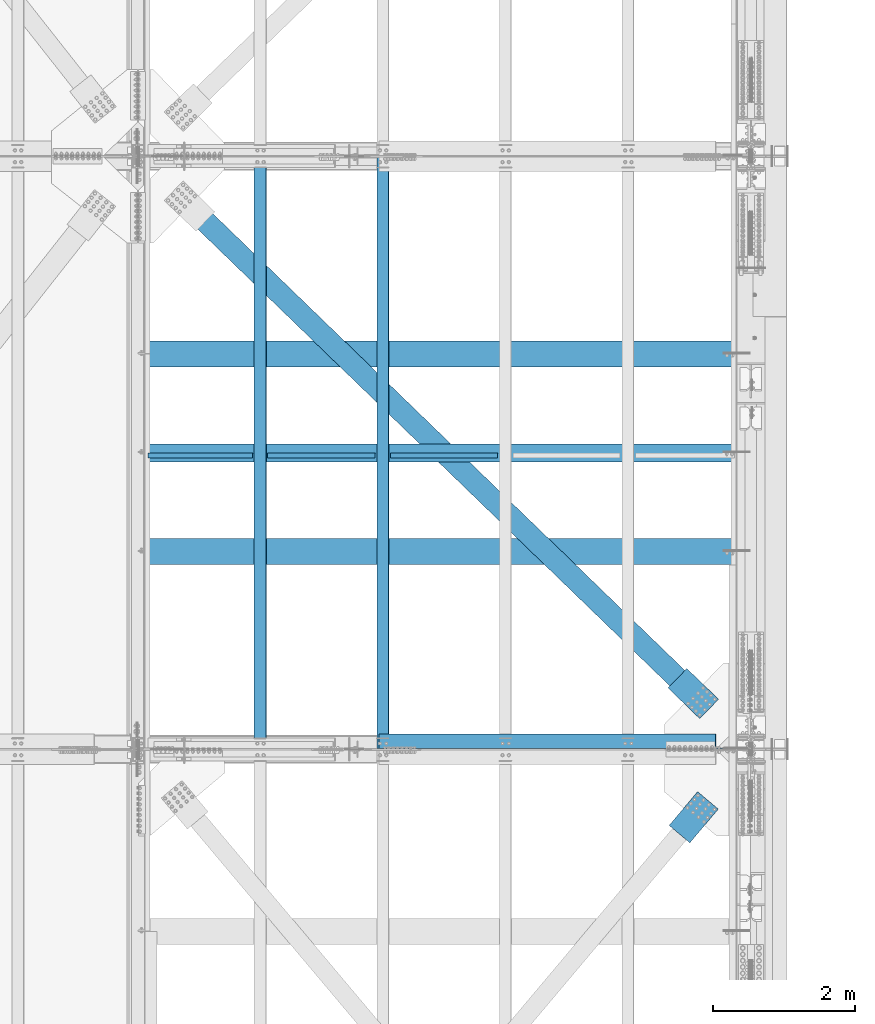
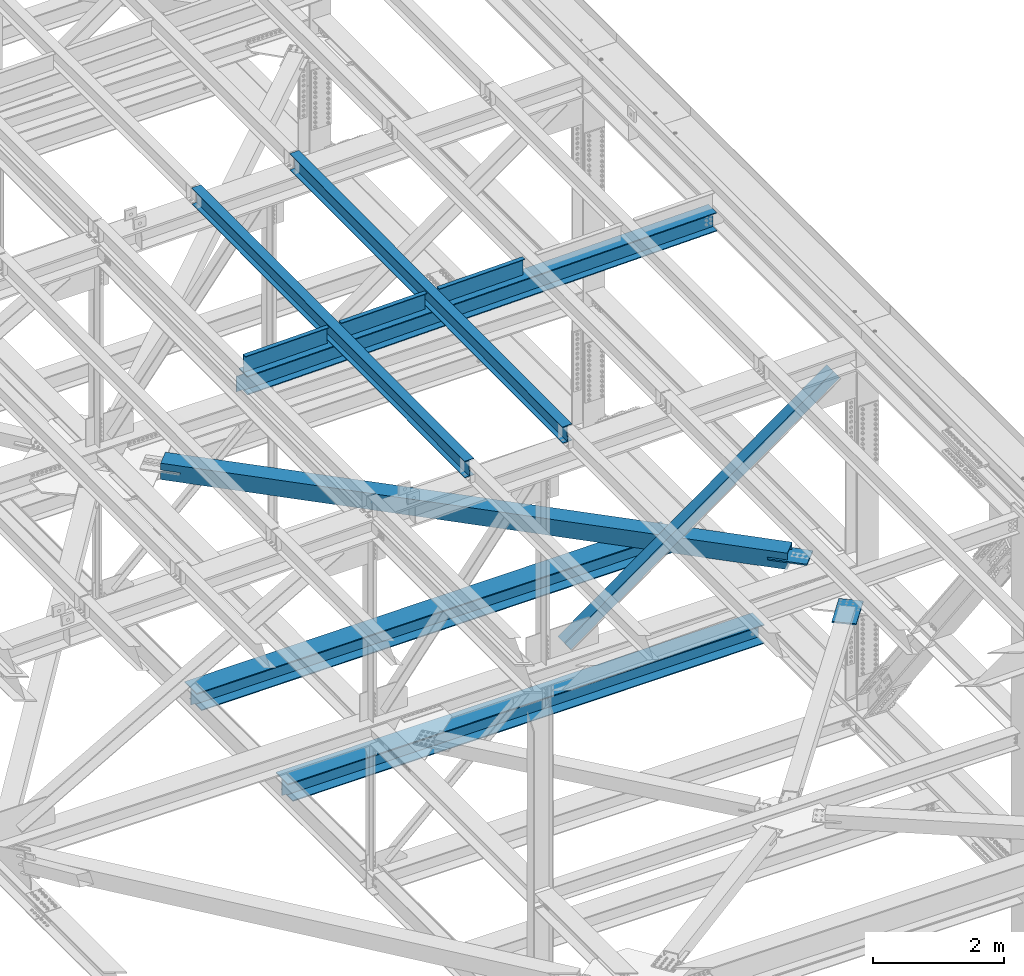
# One storey, part 1960 of 3843: 11 beams, 1 member, 11 elements without a shape of their own.
"""IFC2X3 building model written with IfcOpenShell, lengths in millimetres."""

from ifc_helpers import new_model, si_unit, frame, origin_with_axes, place, context, subcontext, project, spatial, faceted_brep, material, type_object, element, aggregate, save


model = new_model("IFC2X3")

# Units and contexts
model_context = context("Model", 3, precision=1e-05, world=origin_with_axes())
body_context = subcontext(model_context, "Body", "Model", "MODEL_VIEW")
ifc_project = project(units=[si_unit("LENGTHUNIT", "METRE", prefix="MILLI"), si_unit("AREAUNIT", "SQUARE_METRE"), si_unit("VOLUMEUNIT", "CUBIC_METRE"), si_unit("MASSUNIT", "GRAM", prefix="KILO"), si_unit("TIMEUNIT", "SECOND"), si_unit("PLANEANGLEUNIT", "RADIAN"), si_unit("SOLIDANGLEUNIT", "STERADIAN"), si_unit("THERMODYNAMICTEMPERATUREUNIT", "DEGREE_CELSIUS"), si_unit("LUMINOUSINTENSITYUNIT", "LUMEN")], contexts=[model_context])

# Site, building, storey
site_placement = place(None, origin_with_axes())
site = spatial("IfcSite", under=ifc_project, at=site_placement, CompositionType="ELEMENT")
building_placement = place(site_placement, origin_with_axes())
building = spatial("IfcBuilding", under=site, at=building_placement, Name="Undefined", CompositionType="ELEMENT")
storey_placement = place(building_placement, origin_with_axes())
storey = spatial("IfcBuildingStorey", under=building, at=storey_placement, Name="Undefined", CompositionType="ELEMENT", Elevation=0.0)

# Assembly, beam
assembly_1_placement = place(storey_placement, origin_with_axes())
assembly_1 = element("IfcElementAssembly", 1, at=assembly_1_placement, inside=storey, Name="BEAM", AssemblyPlace="NOTDEFINED", PredefinedType="RIGID_FRAME")
ifc_material_1 = material(Name="STEEL/A992")
beam_type_1 = type_object("IfcBeamType", Name="W12X26", PredefinedType="NOTDEFINED")
beam_1_placement = place(assembly_1_placement, frame((80463.9092623644, 33844.6461896289, 46523.0633431853), z_axis=(-0.0211520976960747, -0.00548809500152129, 0.999761206276934), x_axis=(0.0, 0.999984933553015, 0.00548932299754643)))
beam_1 = element("IfcBeam", 2, at=beam_1_placement, type_object=beam_type_1, material=ifc_material_1, Name="BEAM", ObjectType="W12X26", context=body_context, shape_type="Brep", body=[
    faceted_brep([(12.6906062761627, 82.5500000000466, -155.575000000434), (12.7428811673817, 82.5500000000611, -146.050000000425), (8344.06840460598, 82.5500000001339, -146.05000000351), (8344.01612971476, 82.5500000001193, -155.575000003526), (12.7520975927982, 3.17499999961001, -146.050000000228), (8344.07762103139, 3.17499999968277, -146.050000003313), (14.3551942568884, 3.17500000036671, 146.050000000199), (8345.68071769549, 3.17500000043947, 146.049999997114), (14.3459778314718, 82.5500000008033, 146.050000000003), (8345.67150127007, 82.550000000876, 146.049999996918), (14.3982527226908, 82.5500000008469, 155.575000000012), (8345.72377616129, 82.5500000009197, 155.574999996934), (14.4174228875563, -82.5500000000902, 155.575000000426), (8345.74294632617, -82.5500000000175, 155.574999997341), (14.3651479963373, -82.5500000001193, 146.050000000418), (8345.69067143494, -82.5500000000466, 146.049999997318), (14.3559315709208, -3.17499999966822, 146.050000000214), (8345.68145500952, -3.17499999959546, 146.049999997122), (12.7528349068307, -3.17500000042492, -146.050000000214), (8344.07835834543, -3.17500000035216, -146.050000003299), (12.7620513322399, -82.550000000876, -146.050000000017), (8344.08757477084, -82.5500000008033, -146.050000003095), (12.7097764410209, -82.5500000008906, -155.575000000019), (8344.03529987962, -82.5500000008178, -155.575000003111)], [[[0, 1, 2, 3]], [[1, 4, 5, 2]], [[4, 6, 7, 5]], [[6, 8, 9, 7]], [[8, 10, 11, 9]], [[10, 12, 13, 11]], [[12, 14, 15, 13]], [[14, 16, 17, 15]], [[16, 18, 19, 17]], [[18, 20, 21, 19]], [[20, 22, 23, 21]], [[22, 0, 3, 23]], [[5, 7, 9, 11, 13, 15, 17, 19, 21, 23, 3, 2]], [[22, 20, 18, 16, 14, 12, 10, 8, 6, 4, 1, 0]]]),
])
aggregate(assembly_1, [beam_1])

assembly_2_placement = place(storey_placement, origin_with_axes())
assembly_2 = element("IfcElementAssembly", 3, at=assembly_2_placement, inside=storey, Name="BEAM", AssemblyPlace="NOTDEFINED", PredefinedType="RIGID_FRAME")
beam_2_placement = place(assembly_2_placement, frame((78736.7092623646, 33844.5952455108, 46486.5209759278), z_axis=(-0.0211520978613553, -0.0058155520005821, 0.999759355100512), x_axis=(0.0, 0.999983081967479, 0.00581685299981112)))
beam_2 = element("IfcBeam", 4, at=beam_2_placement, type_object=beam_type_1, material=ifc_material_1, Name="BEAM", ObjectType="W12X26", context=body_context, shape_type="Brep", body=[
    faceted_brep([(12.6900579014109, 82.549999999479, -155.575000000033), (12.7454519674648, 82.5499999995227, -146.050000000017), (8344.08640182665, 82.5499999992608, -146.049999987452), (8344.0310077606, 82.5499999992026, -155.574999987468), (12.7552183248699, 3.17499999908614, -146.050000000228), (8344.09616818406, 3.17499999882421, -146.049999987663), (14.4539696838547, 3.17500000091968, 146.050000000294), (8345.79491954304, 3.17500000065775, 146.05000001286), (14.4442033264422, 82.5500000013417, 146.050000000505), (8345.78515318563, 82.5500000010798, 146.050000013071), (14.4995973924961, 82.5500000013999, 155.575000000521), (8345.84054725168, 82.5500000011234, 155.575000013087), (14.5199114159041, -82.5499999994936, 155.575000000084), (8345.86086127509, -82.5499999997555, 155.57500001265), (14.4645173498502, -82.5499999995664, 146.050000000068), (8345.80546720904, -82.5499999998283, 146.050000012634), (14.454750992445, -3.17499999911524, 146.050000000279), (8345.79570085163, -3.17499999939173, 146.050000012845), (12.7559996334676, -3.17500000093423, -146.05000000025), (8344.09694949265, -3.17500000119617, -146.049999987685), (12.7657659908728, -82.5500000013708, -146.050000000461), (8344.10671585005, -82.5500000016327, -146.049999987896), (12.7103719248189, -82.550000001429, -155.575000000477), (8344.051321784, -82.5500000016909, -155.574999987912)], [[[0, 1, 2, 3]], [[1, 4, 5, 2]], [[4, 6, 7, 5]], [[6, 8, 9, 7]], [[8, 10, 11, 9]], [[10, 12, 13, 11]], [[12, 14, 15, 13]], [[14, 16, 17, 15]], [[16, 18, 19, 17]], [[18, 20, 21, 19]], [[20, 22, 23, 21]], [[22, 0, 3, 23]], [[5, 7, 9, 11, 13, 15, 17, 19, 21, 23, 3, 2]], [[22, 20, 18, 16, 14, 12, 10, 8, 6, 4, 1, 0]]]),
])
aggregate(assembly_2, [beam_2])

assembly_3_placement = place(storey_placement, origin_with_axes())
assembly_3 = element("IfcElementAssembly", 5, at=assembly_3_placement, inside=storey, Name="BENT_PLATE", AssemblyPlace="NOTDEFINED", PredefinedType="RIGID_FRAME")
ifc_material_2 = material(Name="STEEL/A36")
beam_type_2 = type_object("IfcBeamType", PredefinedType="NOTDEFINED")
beam_3_placement = place(assembly_3_placement, frame((77894.6595890267, 38019.037499995, 46316.557671359), z_axis=(-0.999817430718778, 0.0, -0.0191077269946473), x_axis=(-0.0191077269946443, 0.0, 0.999817430718778)))
beam_3 = element("IfcBeam", 6, at=beam_3_placement, type_object=beam_type_2, material=ifc_material_2, Name="BENT_PLATE", context=body_context, shape_type="Brep", body=[
    faceted_brep([(2.31375452131033e-09, -4.76249999999709, -736.599999997517), (-2.30647856369615e-09, -4.76249999999709, 736.599999997474), (-2.30647856369615e-09, 4.76249999999709, 736.599999997474), (2.31375452131033e-09, 4.76249999999709, -736.599999997517), (336.54999997931, 4.76249999995343, 736.599999998551), (336.549999983916, 4.76249999995343, -736.59999999647), (327.024999983958, -4.76250000004075, -736.599999996499), (327.024999979338, -4.76250000004075, 736.599999998522), (336.549999979303, -71.4375000011278, 736.599999998551), (336.549999983908, -71.4375000011278, -736.599999996455), (327.02499997933, -71.4375000011278, 736.599999998522), (327.024999983951, -71.4375000011278, -736.599999996499)], [[[0, 1, 2, 3]], [[3, 2, 4, 5]], [[1, 0, 6, 7]], [[5, 4, 8, 9]], [[4, 2, 1, 7, 10, 8]], [[7, 6, 11, 10]], [[6, 0, 3, 5, 9, 11]], [[10, 11, 9, 8]]]),
])
aggregate(assembly_3, [beam_3])

assembly_4_placement = place(storey_placement, origin_with_axes())
assembly_4 = element("IfcElementAssembly", 7, at=assembly_4_placement, inside=storey, Name="BENT_PLATE", AssemblyPlace="NOTDEFINED", PredefinedType="RIGID_FRAME")
beam_4_placement = place(assembly_4_placement, frame((79602.8130669715, 38019.0374999949, 46349.2025616298), z_axis=(-0.999817430718778, 0.0, -0.0191077269946473), x_axis=(-0.0191077269946443, 0.0, 0.999817430718778)))
beam_4 = element("IfcBeam", 8, at=beam_4_placement, type_object=beam_type_2, material=ifc_material_2, Name="BENT_PLATE", context=body_context, shape_type="Brep", body=[
    faceted_brep([(2.38651409745216e-09, -4.76249999999709, -755.649999997448), (-2.37923813983798e-09, -4.76249999999709, 755.649999997433), (-2.37923813983798e-09, 4.76249999999709, 755.649999997433), (2.38651409745216e-09, 4.76249999999709, -755.649999997448), (336.54999997891, 4.76249999995343, 755.649999998495), (336.549999983821, 4.76249999995343, -755.649999996385), (327.024999983856, -4.76250000004075, -755.649999996414), (327.024999978938, -4.76250000004075, 755.649999998466), (336.549999978997, -71.4375000010259, 755.649999998495), (336.549999983719, -71.4375000011714, -755.649999996371), (327.024999979025, -71.4375000010259, 755.649999998481), (327.024999983762, -71.4375000011714, -755.6499999964)], [[[0, 1, 2, 3]], [[3, 2, 4, 5]], [[1, 0, 6, 7]], [[5, 4, 8, 9]], [[4, 2, 1, 7, 10, 8]], [[7, 6, 11, 10]], [[6, 0, 3, 5, 9, 11]], [[10, 11, 9, 8]]]),
])
aggregate(assembly_4, [beam_4])

assembly_5_placement = place(storey_placement, origin_with_axes())
assembly_5 = element("IfcElementAssembly", 9, at=assembly_5_placement, inside=storey, Name="BENT_PLATE", AssemblyPlace="NOTDEFINED", PredefinedType="RIGID_FRAME")
beam_5_placement = place(assembly_5_placement, frame((81330.0130669715, 38019.0374999949, 46382.2114540998), z_axis=(-0.999817430718778, 0.0, -0.0191077269946473), x_axis=(-0.0191077269946443, 0.0, 0.999817430718778)))
beam_5 = element("IfcBeam", 10, at=beam_5_placement, type_object=beam_type_2, material=ifc_material_2, Name="BENT_PLATE", context=body_context, shape_type="Brep", body=[
    faceted_brep([(2.38651409745216e-09, -4.76249999999709, -755.649999997448), (-2.37923813983798e-09, -4.76249999999709, 755.649999997433), (-2.37923813983798e-09, 4.76249999999709, 755.649999997433), (2.38651409745216e-09, 4.76249999999709, -755.649999997448), (336.54999997891, 4.76249999995343, 755.649999998495), (336.549999983821, 4.76249999995343, -755.649999996385), (327.024999983856, -4.76250000004075, -755.649999996414), (327.024999978938, -4.76250000004075, 755.649999998466), (336.549999978997, -71.4375000010259, 755.649999998495), (336.549999983719, -71.4375000011714, -755.649999996371), (327.024999979025, -71.4375000010259, 755.649999998481), (327.024999983762, -71.4375000011714, -755.6499999964)], [[[0, 1, 2, 3]], [[3, 2, 4, 5]], [[1, 0, 6, 7]], [[5, 4, 8, 9]], [[4, 2, 1, 7, 10, 8]], [[7, 6, 11, 10]], [[6, 0, 3, 5, 9, 11]], [[10, 11, 9, 8]]]),
])
aggregate(assembly_5, [beam_5])

assembly_6_placement = place(storey_placement, origin_with_axes())
assembly_6 = element("IfcElementAssembly", 11, at=assembly_6_placement, inside=storey, AssemblyPlace="NOTDEFINED", PredefinedType="RIGID_FRAME")
ifc_material_3 = material(Name="STEEL/A572-50")
beam_type_3 = type_object("IfcBeamType", PredefinedType="NOTDEFINED")
beam_6_placement = place(assembly_6_placement, frame((85061.136272036, 34414.1510652771, 42259.2500000054), z_axis=(0.695386222991622, 0.718636208991341, 0.0), x_axis=(-0.718636212924515, 0.695386218926944, 0.0)))
beam_6 = element("IfcBeam", 12, at=beam_6_placement, type_object=beam_type_3, material=ifc_material_3, Name="PLATE", context=body_context, shape_type="Brep", body=[
    faceted_brep([(5.85714587941766e-10, 12.6999999999971, -190.500000000349), (-6.14818418398499e-10, 12.6999999999971, 190.500000000364), (622.299987794569, 12.6999999999971, 190.499999998057), (622.299987793129, 12.6999999999971, -190.500000002765), (-6.14818418398499e-10, -12.6999999999971, 190.500000000364), (622.299987794569, -12.6999999999971, 190.499999998057), (5.85714587941766e-10, -12.6999999999971, -190.500000000349), (622.299987793129, -12.6999999999971, -190.500000002765)], [[[0, 1, 2, 3]], [[1, 4, 5, 2]], [[4, 6, 7, 5]], [[6, 0, 3, 7]], [[5, 7, 3, 2]], [[6, 4, 1, 0]]]),
])

assembly_7_placement = place(storey_placement, origin_with_axes())
assembly_7 = element("IfcElementAssembly", 13, at=assembly_7_placement, inside=storey, AssemblyPlace="NOTDEFINED", PredefinedType="RIGID_FRAME")
beam_7_placement = place(assembly_7_placement, frame((85043.6867269005, 33126.4830499824, 42259.2500000046), z_axis=(-0.76510760520398, 0.643902440171669, 0.0), x_axis=(-0.643902440171663, -0.765107605203986, 0.0)))
beam_7 = element("IfcBeam", 14, at=beam_7_placement, type_object=beam_type_3, material=ifc_material_3, Name="PLATE", context=body_context, shape_type="Brep", body=[
    faceted_brep([(5.85714587941766e-10, 12.6999999999971, -190.500000000349), (-6.14818418398499e-10, 12.6999999999971, 190.500000000364), (622.299987794569, 12.6999999999971, 190.499999998057), (622.299987793129, 12.6999999999971, -190.500000002765), (-6.14818418398499e-10, -12.6999999999971, 190.500000000364), (622.299987794569, -12.6999999999971, 190.499999998057), (5.85714587941766e-10, -12.6999999999971, -190.500000000349), (622.299987793129, -12.6999999999971, -190.500000002765)], [[[0, 1, 2, 3]], [[1, 4, 5, 2]], [[4, 6, 7, 5]], [[6, 0, 3, 7]], [[5, 7, 3, 2]], [[6, 4, 1, 0]]]),
])
aggregate(assembly_7, [beam_7])

# Assembly, member
assembly_8_placement = place(storey_placement, origin_with_axes())
assembly_8 = element("IfcElementAssembly", 15, at=assembly_8_placement, inside=storey, Name="ANGLE", AssemblyPlace="NOTDEFINED", PredefinedType="RIGID_FRAME")
member_type = type_object("IfcMemberType", Name="L8X8X1/2", PredefinedType="NOTDEFINED")
member_placement = place(assembly_8_placement, frame((85648.7999984443, 33956.625, 46283.3806585524), z_axis=(0.0, 1.0, 0.0), x_axis=(-0.812052527744634, 0.0, -0.583584348816477)))
member = element("IfcMember", 16, at=member_placement, type_object=member_type, material=ifc_material_3, Name="ANGLE", ObjectType="L8X8X1/2", context=body_context, shape_type="Brep", body=[
    faceted_brep([(540.782806112766, 101.59999999942, -101.599999999999), (540.782806112766, 101.59999999942, 101.599999999999), (6380.4931565233, 101.599999987568, 101.599999999999), (6380.4931565233, 101.599999987568, -101.599999999999), (540.782806112751, 88.8999999993575, 101.599999999999), (6380.49315652328, 88.8999999874977, 101.599999999999), (540.782806112751, 88.8999999993575, -88.9000000000015), (6380.49315652328, 88.8999999874977, -88.9000000000015), (540.782806112416, -101.600000001588, -88.9000000000015), (6380.49315652296, -101.600000013441, -88.9000000000015), (540.782806112416, -101.600000001588, -101.599999999999), (6380.49315652296, -101.600000013441, -101.599999999999)], [[[0, 1, 2, 3]], [[1, 4, 5, 2]], [[4, 6, 7, 5]], [[6, 8, 9, 7]], [[8, 10, 11, 9]], [[10, 0, 3, 11]], [[5, 7, 9, 11, 3, 2]], [[10, 8, 6, 4, 1, 0]]]),
])
aggregate(assembly_8, [member])

# Beam
ifc_material_4 = material()
beam_type_4 = type_object("IfcBeamType", Name="HSS12X12X3/4", PredefinedType="NOTDEFINED")
beam_8_placement = place(assembly_6_placement, frame((77012.8000000667, 42202.0999998931, 42246.55), z_axis=(0.695386222991622, 0.718636208991341, 0.0), x_axis=(0.718636212924518, -0.695386218926941, 0.0)))
beam_8 = element("IfcBeam", 17, at=beam_8_placement, type_object=beam_type_4, material=ifc_material_4, ObjectType="HSS12X12X3/4", context=body_context, shape_type="Brep", body=[
    faceted_brep([(1018.02056852169, 1.58800048694684, 152.400000003399), (1018.02056852159, 1.58800048694684, 133.350000003455), (1321.23308036643, 1.58800048694684, 133.350000004619), (1321.23308036657, 1.58800048694684, 152.400000004549), (1326.70067005237, 0.500429278661613, 133.350000004648), (1326.70067005249, 0.500429278661613, 152.400000004578), (1331.33586877244, -2.59671148857888, 133.350000004648), (1331.33586877256, -2.59671148857888, 152.400000004593), (1334.43300953971, -7.23191020862578, 133.350000004662), (1334.43300953983, -7.23191020862578, 152.400000004607), (1321.23308036657, -26.9869995130503, 152.400000004549), (1321.23308036643, -26.9869995130503, 133.350000004619), (1018.02056852159, -26.9869995130503, 133.350000003455), (1018.02056852169, -26.9869995130503, 152.400000003399), (1326.70067005249, -25.899428304765, 152.400000004578), (1326.70067005237, -25.899428304765, 133.350000004648), (1331.33586877256, -22.8022875375245, 152.400000004593), (1331.33586877244, -22.8022875375245, 133.350000004648), (1334.43300953983, -18.1670888174776, 152.400000004607), (1334.43300953971, -18.1670888174776, 133.350000004662), (1335.52058074813, -12.6994991315805, 152.400000004607), (1335.520580748, -12.6994991315805, 133.350000004677), (1018.02056852025, 1.58800048694684, -133.349999995713), (1018.02056852015, 1.58800048694684, -152.399999995658), (1321.23308036463, 1.58800048694684, -152.399999994508), (1321.23308036476, 1.58800048694684, -133.349999994549), (1326.70067005056, 0.500429278661613, -152.399999994479), (1326.70067005069, 0.500429278661613, -133.349999994534), (1331.33586877064, -2.59671148857888, -152.399999994464), (1331.33586877077, -2.59671148857888, -133.34999999452), (1334.4330095379, -7.23191020862578, -152.39999999445), (1334.43300953803, -7.23191020862578, -133.349999994505), (1321.23308036476, -26.9869995130503, -133.349999994549), (1321.23308036463, -26.9869995130503, -152.399999994508), (1018.02056852015, -26.9869995130503, -152.399999995658), (1018.02056852025, -26.9869995130503, -133.349999995713), (1326.70067005069, -25.899428304765, -133.349999994534), (1326.70067005056, -25.899428304765, -152.399999994479), (1331.33586877077, -22.8022875375245, -133.34999999452), (1331.33586877064, -22.8022875375245, -152.399999994464), (1334.43300953803, -18.1670888174776, -133.349999994505), (1334.4330095379, -18.1670888174776, -152.39999999445), (1335.52058074632, -12.6994991315805, -133.349999994505), (1335.52058074619, -12.6994991315805, -152.39999999445), (10881.9582617149, 133.349999999999, -133.349999958227), (10881.9582617163, 133.349999999999, 133.35000004094), (1018.02056852159, 133.349999999999, 133.350000003455), (1018.02056852025, 133.349999999999, -133.349999995713), (10881.9582617149, -26.9875000053944, -133.349999958227), (10881.9582617148, -26.9875000053944, -152.399999958157), (10578.7457621309, -26.9875000053944, -152.399999959322), (10578.745762131, -26.9875000053944, -133.349999959377), (10573.278172445, -25.8999287971092, -152.399999959336), (10573.2781724451, -25.8999287971092, -133.349999959391), (10568.6429737249, -22.8027880298687, -152.399999959351), (10568.642973725, -22.8027880298687, -133.349999959421), (10565.5458329576, -18.1675893098218, -152.39999995938), (10565.5458329578, -18.1675893098218, -133.349999959421), (10564.4582617494, -12.6999996239247, -152.399999959365), (10564.4582617495, -12.6999996239247, -133.349999959435), (10565.5458329576, -7.23241070096992, -152.39999995938), (10565.5458329578, -7.23241070096992, -133.349999959421), (10568.6429737249, -2.59721198092302, -152.399999959351), (10568.642973725, -2.59721198092302, -133.349999959421), (10573.278172445, 0.499928786317469, -152.399999959336), (10573.2781724451, 0.499928786317469, -133.349999959391), (10578.7457621309, 1.58749999460269, -152.399999959322), (10578.745762131, 1.58749999460269, -133.349999959377), (10881.9582617149, 1.58749999460269, -133.349999958227), (10881.9582617148, 1.58749999460269, -152.399999958157), (10881.9582617148, 152.400000000001, -152.399999958157), (10881.9582617164, 152.400000000001, 152.4000000409), (10881.9582617164, 1.58749999460269, 152.4000000409), (10881.9582617163, 1.58749999460269, 133.35000004094), (10881.9582617163, -133.349999999999, 133.35000004094), (10881.9582617149, -133.349999999999, -133.349999958227), (1018.02056852025, -133.349999999999, -133.349999995713), (1018.02056852159, -133.349999999999, 133.350000003455), (10578.7457621327, 1.58749999460269, 133.350000039791), (10573.2781724468, 0.499928786317469, 133.350000039776), (10568.6429737267, -2.59721198092302, 133.350000039762), (10565.5458329594, -7.23241070096992, 133.350000039747), (10564.4582617512, -12.6999996239247, 133.350000039747), (10565.5458329594, -18.1675893098218, 133.350000039747), (10568.6429737267, -22.8027880298687, 133.350000039762), (10573.2781724468, -25.8999287971092, 133.350000039776), (10578.7457621327, -26.9875000053944, 133.350000039791), (10881.9582617163, -26.9875000053944, 133.35000004094), (10578.7457621328, 1.58749999460269, 152.400000039735), (10573.2781724469, 0.499928786317469, 152.400000039721), (10568.6429737268, -2.59721198092302, 152.400000039706), (10565.5458329596, -7.23241070096992, 152.400000039692), (10564.4582617513, -12.6999996239247, 152.400000039677), (10565.5458329596, -18.1675893098218, 152.400000039692), (10568.6429737268, -22.8027880298687, 152.400000039706), (10573.2781724469, -25.8999287971092, 152.400000039721), (10578.7457621328, -26.9875000053944, 152.400000039735), (10881.9582617164, -26.9875000053944, 152.4000000409), (10881.9582617164, -152.400000000001, 152.4000000409), (10881.9582617148, -152.400000000001, -152.399999958157), (1018.02056852169, -152.400000000001, 152.400000003399), (1018.02056852015, -152.400000000001, -152.399999995658), (1018.02056852015, 152.400000000001, -152.399999995658), (1018.02056852169, 152.400000000001, 152.400000003399)], [[[0, 1, 2, 3]], [[3, 2, 4, 5]], [[5, 4, 6, 7]], [[7, 6, 8, 9]], [[10, 11, 12, 13]], [[14, 15, 11, 10]], [[16, 17, 15, 14]], [[18, 19, 17, 16]], [[20, 21, 19, 18]], [[9, 8, 21, 20]], [[22, 23, 24, 25]], [[25, 24, 26, 27]], [[27, 26, 28, 29]], [[29, 28, 30, 31]], [[32, 33, 34, 35]], [[36, 37, 33, 32]], [[38, 39, 37, 36]], [[40, 41, 39, 38]], [[42, 43, 41, 40]], [[31, 30, 43, 42]], [[44, 45, 46, 47]], [[48, 49, 50, 51]], [[51, 50, 52, 53]], [[53, 52, 54, 55]], [[55, 54, 56, 57]], [[57, 56, 58, 59]], [[59, 58, 60, 61]], [[61, 60, 62, 63]], [[63, 62, 64, 65]], [[65, 64, 66, 67]], [[68, 67, 66, 69]], [[45, 44, 68, 69, 70, 71, 72, 73]], [[74, 75, 76, 77]], [[6, 4, 2, 1, 46, 45, 73, 78, 79, 80, 81, 82, 83, 84, 85, 86, 87, 74, 77, 12, 11, 15, 17, 19, 21, 8]], [[72, 88, 78, 73]], [[89, 79, 78, 88]], [[90, 80, 79, 89]], [[91, 81, 80, 90]], [[92, 82, 81, 91]], [[93, 83, 82, 92]], [[94, 84, 83, 93]], [[95, 85, 84, 94]], [[96, 86, 85, 95]], [[97, 87, 86, 96]], [[98, 99, 49, 48, 75, 74, 87, 97]], [[99, 98, 100, 101]], [[77, 76, 35, 34, 101, 100, 13, 12]], [[28, 26, 24, 23, 102, 70, 69, 66, 64, 62, 60, 58, 56, 54, 52, 50, 49, 99, 101, 34, 33, 37, 39, 41, 43, 30]], [[71, 70, 102, 103]], [[16, 14, 10, 13, 100, 98, 97, 96, 95, 94, 93, 92, 91, 90, 89, 88, 72, 71, 103, 0, 3, 5, 7, 9, 20, 18]], [[103, 102, 23, 22, 47, 46, 1, 0]], [[38, 36, 32, 35, 76, 75, 48, 51, 53, 55, 57, 59, 61, 63, 65, 67, 68, 44, 47, 22, 25, 27, 29, 31, 42, 40]]]),
])

aggregate(assembly_6, [beam_6, beam_8])

# Assembly, beam
assembly_9_placement = place(storey_placement, origin_with_axes())
assembly_9 = element("IfcElementAssembly", 18, at=assembly_9_placement, inside=storey, Name="BEAM", AssemblyPlace="NOTDEFINED", PredefinedType="RIGID_FRAME")
beam_type_5 = type_object("IfcBeamType", Name="W14X61", PredefinedType="NOTDEFINED")
beam_9_placement = place(assembly_9_placement, frame((77012.7999994638, 38023.8, 46123.2787840905), z_axis=(-0.0191077269946443, 0.0, 0.999817430718778), x_axis=(0.999817430718778, 0.0, 0.0191077269946253)))
beam_9 = element("IfcBeam", 19, at=beam_9_placement, type_object=beam_type_5, material=ifc_material_1, Name="BEAM", ObjectType="W14X61", context=body_context, shape_type="Brep", body=[
    faceted_brep([(15.4987301189685, -4.76249999999709, -144.462499978908), (15.4987301189685, 4.76249999999709, -144.462499978908), (129.191949203145, 4.76249999999709, -144.462499981149), (129.191949203145, -4.76249999999709, -144.462499981149), (134.052028721344, 4.76249999999709, -145.42922990377), (134.052028721344, -4.76249999999709, -145.42922990377), (138.172205189665, 4.76249999999709, -148.182243804302), (138.172205189665, -4.76249999999709, -148.182243804302), (140.925219090263, 4.76249999999709, -152.302420272528), (140.925219090263, -4.76249999999709, -152.302420272528), (141.891949012905, -4.76249999999709, -157.162499790633), (141.891949012905, 4.76249999999709, -157.162499790633), (141.891949012876, 4.76249999999709, -160.337500000358), (141.891949012876, 127.0, -160.337500000358), (141.891949012715, 127.0, -176.212500000358), (141.891949012715, -127.0, -176.212500000358), (141.891949012876, -127.0, -160.337500000358), (141.891949012876, -4.76249999999709, -160.337500000358), (8418.2698977901, -127.0, 160.33749997618), (8418.26989778999, -127.0, 176.21249997618), (141.891949008583, -127.0, 176.212499999543), (141.891949008656, -127.0, 160.33749999955), (8418.26989778999, 127.0, 176.21249997618), (141.891949008583, 127.0, 176.212499999543), (8418.2698977901, 127.0, 160.33749997618), (141.891949008656, 127.0, 160.33749999955), (8418.2698977901, 4.76249999999709, 160.33749997618), (141.891949008656, 4.76249999999709, 160.33749999955), (129.191949199827, -4.76249999999709, 144.462500016765), (129.191949199827, 4.76249999999709, 144.462500016765), (21.0204382329975, 4.76249999999709, 144.462500015492), (21.0204382329975, -4.76249999999709, 144.462500015492), (134.052028717953, -4.76249999999709, 145.429229939335), (134.052028717953, 4.76249999999709, 145.429229939335), (138.172205186143, -4.76249999999709, 148.182243839794), (138.172205186143, 4.76249999999709, 148.182243839794), (140.925219086595, -4.76249999999709, 152.30242030794), (140.925219086595, 4.76249999999709, 152.30242030794), (141.891949009107, -4.76249999999709, 157.162499825972), (141.891949009107, 4.76249999999709, 157.162499825972), (141.891949008656, -4.76249999999709, 160.33749999955), (8418.2698977901, -4.76249999999709, 160.33749997618), (8418.26989779246, 4.76249999999709, -160.337500023721), (8418.26989779246, -4.76249999999709, -160.337500023721), (8418.26989779246, -127.0, -160.337500023721), (8418.26989779258, -127.0, -176.212500023721), (8418.26989779258, 127.0, -176.212500023721), (8418.26989779246, 127.0, -160.337500023721), (16.5043014397961, 4.76249999999709, -91.8456850613438), (20.9105432831129, 4.76249999999709, 138.712214462241)], [[[0, 1, 2, 3]], [[3, 2, 4, 5]], [[5, 4, 6, 7]], [[7, 6, 8, 9]], [[10, 11, 12, 13, 14, 15, 16, 17]], [[9, 8, 11, 10]], [[18, 19, 20, 21]], [[19, 22, 23, 20]], [[22, 24, 25, 23]], [[24, 26, 27, 25]], [[28, 29, 30, 31]], [[32, 33, 29, 28]], [[34, 35, 33, 32]], [[36, 37, 35, 34]], [[38, 39, 37, 36]], [[20, 23, 25, 27, 39, 38, 40, 21]], [[41, 18, 21, 40]], [[42, 26, 24, 22, 19, 18, 41, 43, 44, 45, 46, 47]], [[44, 43, 17, 16]], [[45, 44, 16, 15]], [[46, 45, 15, 14]], [[47, 46, 14, 13]], [[42, 47, 13, 12]], [[6, 4, 2, 1, 48, 49, 30, 29, 33, 35, 37, 39, 27, 26, 42, 12, 11, 8]], [[31, 30, 49, 48, 1, 0]], [[43, 41, 40, 38, 36, 34, 32, 28, 31, 0, 3, 5, 7, 9, 10, 17]]]),
])
aggregate(assembly_9, [beam_9])

assembly_10_placement = place(storey_placement, origin_with_axes())
assembly_10 = element("IfcElementAssembly", 20, at=assembly_10_placement, inside=storey, Name="BEAM", AssemblyPlace="NOTDEFINED", PredefinedType="RIGID_FRAME")
beam_type_6 = type_object("IfcBeamType", Name="W14X90", PredefinedType="NOTDEFINED")
beam_10_placement = place(assembly_10_placement, frame((77011.8857484652, 39416.434376, 39446.1976494336), z_axis=(-0.00514245299743198, 0.0, 0.999986777501167), x_axis=(0.999986777501167, 0.0, 0.00514245299743492)))
beam_10 = element("IfcBeam", 21, at=beam_10_placement, type_object=beam_type_6, material=ifc_material_1, Name="BEAM", ObjectType="W14X90", context=body_context, shape_type="Brep", body=[
    faceted_brep([(18.4197664583335, -5.55624999999418, -146.05000000156), (18.4197664583335, 5.55624999999418, -146.05000000156), (94.4564916097588, 5.55624999999418, -146.050000001698), (94.4564916097588, -5.55624999999418, -146.050000001698), (99.3165711278562, 5.55624999999418, -147.016729924304), (99.3165711278562, -5.55624999999418, -147.016729924304), (103.436747596032, 5.55624999999418, -149.769743824807), (103.436747596032, -5.55624999999418, -149.769743824807), (106.189761496527, 5.55624999999418, -153.889920293004), (106.189761496527, -5.55624999999418, -153.889920293004), (107.156491419111, -5.55624999999418, -158.749999811094), (107.156491419111, 5.55624999999418, -158.749999811094), (107.156491419111, 5.55624999999418, -160.337500000664), (107.156491419111, 184.149999999994, -160.337500000664), (107.156491419082, 184.149999999994, -177.800000000716), (107.156491419082, -184.149999999994, -177.800000000716), (107.156491419111, -184.149999999994, -160.337500000664), (107.156491419111, -5.55624999999418, -160.337500000664), (19.9952248293848, 5.55625000000146, 160.337499999732), (19.9952248293848, 184.150000000001, 160.337499999732), (8421.95005102019, 184.150000000001, 160.337499986934), (8421.95005102019, 5.55625000000146, 160.337499986934), (20.0850185756426, 184.150000000001, 177.799999999705), (8422.03984476643, 184.150000000001, 177.799999986906), (20.0850185756426, -184.150000000001, 177.799999999705), (8422.03984476643, -184.150000000001, 177.799999986906), (19.9952248293848, -184.150000000001, 160.337499999732), (8421.95005102019, -184.150000000001, 160.337499986934), (19.9952248293848, -5.55625000000146, 160.337499999732), (8421.95005102019, -5.55625000000146, 160.337499986934), (8420.30113757667, 5.55624999999418, -160.337500015696), (8420.30113757667, -5.55624999999418, -160.337500015696), (8420.30113757667, -184.149999999994, -160.337500015696), (8420.21133630379, -184.149999999994, -177.800000015741), (8420.21133630379, 184.149999999994, -177.800000015741), (8420.30113757667, 184.149999999994, -160.337500015696), (18.6389191982016, 5.55624999999418, -103.434181786943), (19.8246373081929, 5.55625000000146, 127.162755505298)], [[[0, 1, 2, 3]], [[3, 2, 4, 5]], [[5, 4, 6, 7]], [[7, 6, 8, 9]], [[10, 11, 12, 13, 14, 15, 16, 17]], [[9, 8, 11, 10]], [[18, 19, 20, 21]], [[19, 22, 23, 20]], [[22, 24, 25, 23]], [[24, 26, 27, 25]], [[26, 28, 29, 27]], [[30, 21, 20, 23, 25, 27, 29, 31, 32, 33, 34, 35]], [[32, 31, 17, 16]], [[33, 32, 16, 15]], [[34, 33, 15, 14]], [[35, 34, 14, 13]], [[30, 35, 13, 12]], [[6, 4, 2, 1, 36, 37, 18, 21, 30, 12, 11, 8]], [[28, 26, 24, 22, 19, 18, 37, 36, 1, 0]], [[31, 29, 28, 0, 3, 5, 7, 9, 10, 17]]]),
])
aggregate(assembly_10, [beam_10])

assembly_11_placement = place(storey_placement, origin_with_axes())
assembly_11 = element("IfcElementAssembly", 22, at=assembly_11_placement, inside=storey, Name="BEAM", AssemblyPlace="NOTDEFINED", PredefinedType="RIGID_FRAME")
beam_11_placement = place(assembly_11_placement, frame((77012.0860130594, 36630.967188, 39446.1985664246), z_axis=(-0.00401615300090635, 0.0, 0.999991935225016), x_axis=(0.999991935225016, 0.0, 0.00401615300090405)))
beam_11 = element("IfcBeam", 23, at=beam_11_placement, type_object=beam_type_6, material=ifc_material_1, Name="BEAM", ObjectType="W14X90", context=body_context, shape_type="Brep", body=[
    faceted_brep([(18.3839110966655, -5.55624999999418, -146.0499999967), (18.3839110966655, 5.55624999999418, -146.0499999967), (94.4563974007469, 5.55624999999418, -146.049999999617), (94.4563974007469, -5.55624999999418, -146.049999999617), (99.3164769188734, 5.55624999999418, -147.016729922238), (99.3164769188734, -5.55624999999418, -147.016729922238), (103.436653387122, 5.55624999999418, -149.769743822791), (103.436653387122, -5.55624999999418, -149.769743822791), (106.189667287676, 5.55624999999418, -153.889920291032), (106.189667287676, -5.55624999999418, -153.889920291032), (107.156397210303, -5.55624999999418, -158.749999809166), (107.156397210303, 5.55624999999418, -158.749999809166), (107.156397210303, 5.55624999999418, -160.337500000613), (107.156397210303, 184.149999999994, -160.337500000613), (107.156397210114, 184.149999999994, -177.80000000065), (107.156397210114, -184.149999999994, -177.80000000065), (107.156397210303, -184.149999999994, -160.337500000613), (107.156397210303, -5.55624999999418, -160.337500000613), (19.6142583780165, 5.55625000000146, 160.337500000533), (19.6142583780165, 184.150000000001, 160.337500000533), (8421.52575182472, 184.150000000001, 160.337500027126), (8421.52575182472, 5.55625000000146, 160.337500027126), (19.6843826681143, 184.150000000001, 177.800000000585), (8421.59587611482, 184.150000000001, 177.800000027171), (19.6843826681143, -184.150000000001, 177.800000000585), (8421.59587611482, -184.150000000001, 177.800000027171), (19.6142583780165, -184.150000000001, 160.337500000533), (8421.52575182472, -184.150000000001, 160.337500027126), (19.6142583780165, -5.55625000000146, 160.337500000533), (8421.52575182472, -5.55625000000146, 160.337500027126), (8420.23803940228, 5.55624999999418, -160.337500026537), (8420.23803940228, -5.55624999999418, -160.337500026537), (8420.23803940228, -184.149999999994, -160.337500026537), (8420.16790676503, -184.149999999994, -177.800000026567), (8420.16790676503, 184.149999999994, -177.800000026567), (8420.23803940228, 184.149999999994, -160.337500026537), (18.5548808379099, 5.55625000000146, -103.470950219642), (19.4808954930486, 5.55625000000146, 127.12719048727)], [[[0, 1, 2, 3]], [[3, 2, 4, 5]], [[5, 4, 6, 7]], [[7, 6, 8, 9]], [[10, 11, 12, 13, 14, 15, 16, 17]], [[9, 8, 11, 10]], [[18, 19, 20, 21]], [[19, 22, 23, 20]], [[22, 24, 25, 23]], [[24, 26, 27, 25]], [[26, 28, 29, 27]], [[30, 21, 20, 23, 25, 27, 29, 31, 32, 33, 34, 35]], [[32, 31, 17, 16]], [[33, 32, 16, 15]], [[34, 33, 15, 14]], [[35, 34, 14, 13]], [[30, 35, 13, 12]], [[6, 4, 2, 1, 36, 37, 18, 21, 30, 12, 11, 8]], [[28, 26, 24, 22, 19, 18, 37, 36, 1, 0]], [[31, 29, 28, 0, 3, 5, 7, 9, 10, 17]]]),
])
aggregate(assembly_11, [beam_11])

save(model, "model.ifc")
